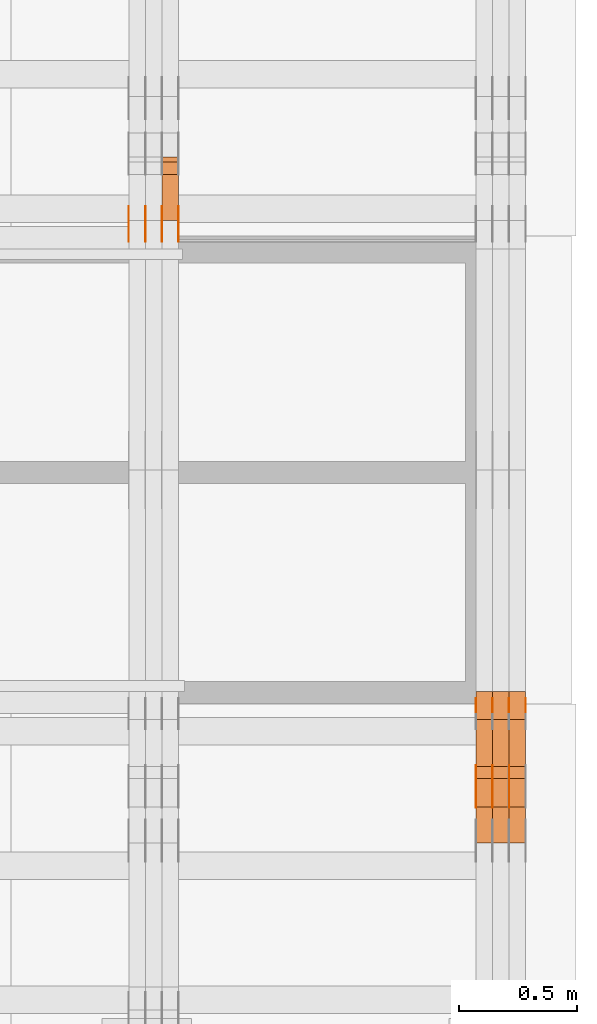
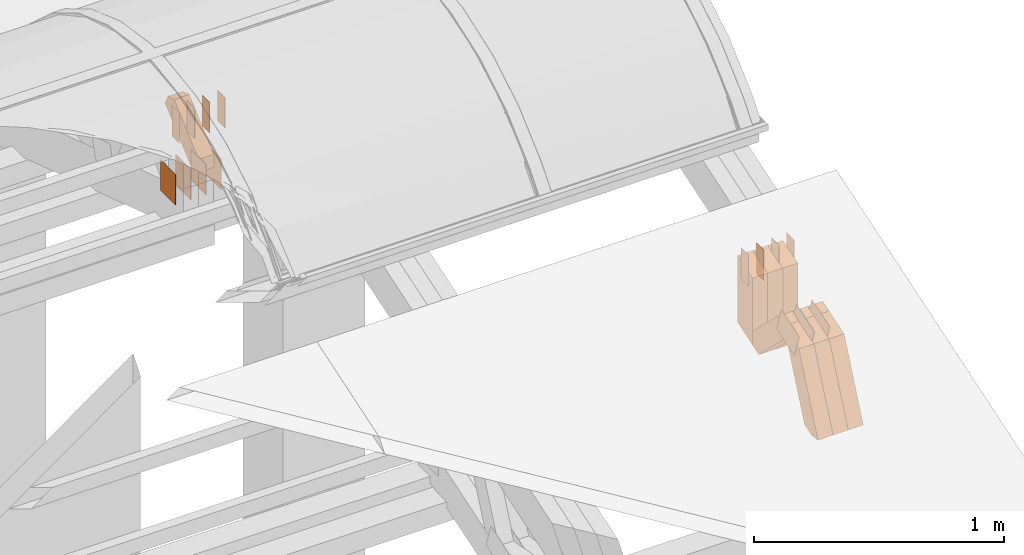
# One storey, part 324 of 385: 32 proxies.
"""IFC2X3 building model written with IfcOpenShell, lengths in millimetres."""

from ifc_helpers import new_model, entity, si_unit, converted_unit, derived_unit, direction, frame, origin, origin_2d_with_axis, place, context, subcontext, project, spatial, polyline, rectangle, outline, extrude, source, transform, mapped, material, type_object, type_shapes, element, save


model = new_model("IFC2X3")

# Units and contexts
model_context = context("Model", 3, precision=0.01, world=origin(), true_north=direction((6.12303176911189e-17, 1.0)))
body_context = subcontext(model_context, "Body", "Model", "MODEL_VIEW")
ifc_project = project(units=[si_unit("LENGTHUNIT", "METRE", prefix="MILLI"), si_unit("AREAUNIT", "SQUARE_METRE"), si_unit("VOLUMEUNIT", "CUBIC_METRE"), converted_unit("PLANEANGLEUNIT", "DEGREE", entity("IfcRatioMeasure", 0.0174532925199433), si_unit("PLANEANGLEUNIT", "RADIAN"), dimensions=[0, 0, 0, 0, 0, 0, 0]), si_unit("MASSUNIT", "GRAM", prefix="KILO"), derived_unit("MASSDENSITYUNIT", [(si_unit("MASSUNIT", "GRAM", prefix="KILO"), 1), (si_unit("LENGTHUNIT", "METRE"), -3)]), si_unit("TIMEUNIT", "SECOND"), si_unit("FREQUENCYUNIT", "HERTZ"), si_unit("THERMODYNAMICTEMPERATUREUNIT", "DEGREE_CELSIUS"), derived_unit("THERMALTRANSMITTANCEUNIT", [(si_unit("MASSUNIT", "GRAM", prefix="KILO"), 1), (si_unit("THERMODYNAMICTEMPERATUREUNIT", "KELVIN"), -1), (si_unit("TIMEUNIT", "SECOND"), -3)]), derived_unit("VOLUMETRICFLOWRATEUNIT", [(si_unit("LENGTHUNIT", "METRE"), 3), (si_unit("TIMEUNIT", "SECOND"), -1)]), si_unit("ELECTRICCURRENTUNIT", "AMPERE"), si_unit("ELECTRICVOLTAGEUNIT", "VOLT"), si_unit("POWERUNIT", "WATT"), si_unit("FORCEUNIT", "NEWTON", prefix="KILO"), si_unit("ILLUMINANCEUNIT", "LUX"), si_unit("LUMINOUSFLUXUNIT", "LUMEN"), si_unit("LUMINOUSINTENSITYUNIT", "CANDELA"), derived_unit("USERDEFINED", [(si_unit("MASSUNIT", "GRAM", prefix="KILO"), -1), (si_unit("LENGTHUNIT", "METRE"), -2), (si_unit("TIMEUNIT", "SECOND"), 3), (si_unit("LUMINOUSFLUXUNIT", "LUMEN"), 1)]), derived_unit("LINEARVELOCITYUNIT", [(si_unit("LENGTHUNIT", "METRE"), 1), (si_unit("TIMEUNIT", "SECOND"), -1)]), si_unit("PRESSUREUNIT", "PASCAL"), derived_unit("USERDEFINED", [(si_unit("LENGTHUNIT", "METRE"), -2), (si_unit("MASSUNIT", "GRAM", prefix="KILO"), 1), (si_unit("TIMEUNIT", "SECOND"), -2)])], contexts=[model_context])

# Site, building, storey
site_placement = place(None, origin())
site = spatial("IfcSite", under=ifc_project, at=site_placement, CompositionType="ELEMENT")
building_placement = place(site_placement, origin())
building = spatial("IfcBuilding", under=site, at=building_placement, CompositionType="ELEMENT")
storey_placement = place(building_placement, origin())
storey = spatial("IfcBuildingStorey", under=building, at=storey_placement, Name="Default", CompositionType="ELEMENT", Elevation=0.0)

# Proxies
ifc_material_1 = material(Name="IfcSurfaceStyle #614002")
building_element_proxy_type_1 = type_object("IfcBuildingElementProxyType", PredefinedType="NOTDEFINED", material=ifc_material_1)
shared_shape_1 = source(origin(), body_context, "Body", "SweptSolid", [
    extrude(outline(polyline([(-74.999875428623, -60.0000016373506), (74.9998605591059, -60.0000016373506), (74.9998754286239, 60.0000016373506), (-74.9998605591068, 60.0000016373506), (-74.999875428623, -60.0000016373506)])), frame((75.0002691827262, 60.0000190504561, 0.0), z_axis=(0.0, 0.0, 1.0), x_axis=(-1.0, 0.0, 0.0)), (0.0, 0.0, 1.0), 1.3),
])
type_shapes(building_element_proxy_type_1, [shared_shape_1])
proxy_1_placement = place(building_placement, frame((49791.3, 13285.0865109705, 3819.37496637467), z_axis=(-1.0, 0.0, 0.0), x_axis=(0.0, 0.951056516295154, 0.309016994374948)))
element("IfcBuildingElementProxy", 1, at=proxy_1_placement, inside=storey, type_object=building_element_proxy_type_1, material=ifc_material_1, context=body_context, shape_type="MappedRepresentation", body=[
    mapped(shared_shape_1, transform((0.0, 0.0, 0.0), scale=1.0)),
])
ifc_material_2 = material(Name="IfcSurfaceStyle #613945")
building_element_proxy_type_2 = type_object("IfcBuildingElementProxyType", PredefinedType="NOTDEFINED", material=ifc_material_2)
shared_shape_2 = source(origin(), body_context, "Body", "SweptSolid", [
    extrude(outline(polyline([(-74.999875428623, -60.0000016373506), (74.9998605591059, -60.0000016373506), (74.9998754286239, 60.0000016373506), (-74.9998605591068, 60.0000016373506), (-74.999875428623, -60.0000016373506)])), frame((75.0002691827262, 60.0000190504561, 0.0), z_axis=(0.0, 0.0, 1.0), x_axis=(-1.0, 0.0, 0.0)), (0.0, 0.0, 1.0), 1.29999999999999),
])
type_shapes(building_element_proxy_type_2, [shared_shape_2])
proxy_2_placement = place(building_placement, frame((49720.0, 13285.0865109705, 3819.37496637467), z_axis=(-1.0, 0.0, 0.0), x_axis=(0.0, 0.951056516295154, 0.309016994374948)))
element("IfcBuildingElementProxy", 2, at=proxy_2_placement, inside=storey, type_object=building_element_proxy_type_2, material=ifc_material_2, context=body_context, shape_type="MappedRepresentation", body=[
    mapped(shared_shape_2, transform((0.0, 0.0, 0.0), scale=1.0)),
])
ifc_material_3 = material(Name="IfcSurfaceStyle #613888")
building_element_proxy_type_3 = type_object("IfcBuildingElementProxyType", PredefinedType="NOTDEFINED", material=ifc_material_3)
shared_shape_3 = source(origin(), body_context, "Body", "SweptSolid", [
    extrude(outline(polyline([(-74.999875428623, -60.0000016373506), (74.9998605591059, -60.0000016373506), (74.9998754286239, 60.0000016373506), (-74.9998605591068, 60.0000016373506), (-74.999875428623, -60.0000016373506)])), frame((75.0002691827262, 60.0000190504561, 0.0), z_axis=(0.0, 0.0, 1.0), x_axis=(-1.0, 0.0, 0.0)), (0.0, 0.0, 1.0), 1.29999999999999),
])
type_shapes(building_element_proxy_type_3, [shared_shape_3])
proxy_3_placement = place(building_placement, frame((49721.3, 13285.0865109705, 3819.37496637467), z_axis=(-1.0, 0.0, 0.0), x_axis=(0.0, 0.951056516295154, 0.309016994374948)))
element("IfcBuildingElementProxy", 3, at=proxy_3_placement, inside=storey, type_object=building_element_proxy_type_3, material=ifc_material_3, context=body_context, shape_type="MappedRepresentation", body=[
    mapped(shared_shape_3, transform((0.0, 0.0, 0.0), scale=1.0)),
])
ifc_material_4 = material(Name="IfcSurfaceStyle #613831")
building_element_proxy_type_4 = type_object("IfcBuildingElementProxyType", PredefinedType="NOTDEFINED", material=ifc_material_4)
shared_shape_4 = source(origin(), body_context, "Body", "SweptSolid", [
    extrude(outline(polyline([(-74.999875428623, -60.0000016373506), (74.9998605591059, -60.0000016373506), (74.9998754286239, 60.0000016373506), (-74.9998605591068, 60.0000016373506), (-74.999875428623, -60.0000016373506)])), frame((75.0002691827262, 60.0000190504561, 0.0), z_axis=(0.0, 0.0, 1.0), x_axis=(-1.0, 0.0, 0.0)), (0.0, 0.0, 1.0), 1.29999999999999),
])
type_shapes(building_element_proxy_type_4, [shared_shape_4])
proxy_4_placement = place(building_placement, frame((49650.0, 13285.0865109705, 3819.37496637467), z_axis=(-1.0, 0.0, 0.0), x_axis=(0.0, 0.951056516295154, 0.309016994374948)))
element("IfcBuildingElementProxy", 4, at=proxy_4_placement, inside=storey, type_object=building_element_proxy_type_4, material=ifc_material_4, context=body_context, shape_type="MappedRepresentation", body=[
    mapped(shared_shape_4, transform((0.0, 0.0, 0.0), scale=1.0)),
])
ifc_material_5 = material(Name="IfcSurfaceStyle #613432")
building_element_proxy_type_5 = type_object("IfcBuildingElementProxyType", PredefinedType="NOTDEFINED", material=ifc_material_5)
shared_shape_5 = source(origin(), body_context, "Body", "SweptSolid", [
    extrude(rectangle(XDim=150.0, YDim=60.0, at=origin_2d_with_axis()), frame((75.0000705696166, 30.0, 0.0), z_axis=(0.0, 0.0, 1.0), x_axis=(-1.0, 0.0, 0.0)), (0.0, 0.0, 1.0), 1.3),
])
type_shapes(building_element_proxy_type_5, [shared_shape_5])
proxy_5_placement = place(building_placement, frame((49861.3, 13750.0, 3972.59919166337), z_axis=(-1.0, 0.0, 0.0), x_axis=(0.0, 0.0, -1.0)))
element("IfcBuildingElementProxy", 5, at=proxy_5_placement, inside=storey, type_object=building_element_proxy_type_5, material=ifc_material_5, context=body_context, shape_type="MappedRepresentation", body=[
    mapped(shared_shape_5, transform((0.0, 0.0, 0.0), scale=1.0)),
])
ifc_material_6 = material(Name="IfcSurfaceStyle #613375")
building_element_proxy_type_6 = type_object("IfcBuildingElementProxyType", PredefinedType="NOTDEFINED", material=ifc_material_6)
shared_shape_6 = source(origin(), body_context, "Body", "SweptSolid", [
    extrude(rectangle(XDim=150.0, YDim=60.0, at=origin_2d_with_axis()), frame((75.0000705696166, 30.0, 0.0), z_axis=(0.0, 0.0, 1.0), x_axis=(-1.0, 0.0, 0.0)), (0.0, 0.0, 1.0), 1.3),
])
type_shapes(building_element_proxy_type_6, [shared_shape_6])
proxy_6_placement = place(building_placement, frame((49790.0, 13750.0, 3972.59919166337), z_axis=(-1.0, 0.0, 0.0), x_axis=(0.0, 0.0, -1.0)))
element("IfcBuildingElementProxy", 6, at=proxy_6_placement, inside=storey, type_object=building_element_proxy_type_6, material=ifc_material_6, context=body_context, shape_type="MappedRepresentation", body=[
    mapped(shared_shape_6, transform((0.0, 0.0, 0.0), scale=1.0)),
])
ifc_material_7 = material(Name="IfcSurfaceStyle #613318")
building_element_proxy_type_7 = type_object("IfcBuildingElementProxyType", PredefinedType="NOTDEFINED", material=ifc_material_7)
shared_shape_7 = source(origin(), body_context, "Body", "SweptSolid", [
    extrude(rectangle(XDim=150.0, YDim=60.0, at=origin_2d_with_axis()), frame((75.0000705696166, 30.0, 0.0), z_axis=(0.0, 0.0, 1.0), x_axis=(-1.0, 0.0, 0.0)), (0.0, 0.0, 1.0), 1.3),
])
type_shapes(building_element_proxy_type_7, [shared_shape_7])
proxy_7_placement = place(building_placement, frame((49791.3, 13750.0, 3972.59919166337), z_axis=(-1.0, 0.0, 0.0), x_axis=(0.0, 0.0, -1.0)))
element("IfcBuildingElementProxy", 7, at=proxy_7_placement, inside=storey, type_object=building_element_proxy_type_7, material=ifc_material_7, context=body_context, shape_type="MappedRepresentation", body=[
    mapped(shared_shape_7, transform((0.0, 0.0, 0.0), scale=1.0)),
])
ifc_material_8 = material(Name="IfcSurfaceStyle #613261")
building_element_proxy_type_8 = type_object("IfcBuildingElementProxyType", PredefinedType="NOTDEFINED", material=ifc_material_8)
shared_shape_8 = source(origin(), body_context, "Body", "SweptSolid", [
    extrude(rectangle(XDim=150.0, YDim=60.0, at=origin_2d_with_axis()), frame((75.0000705696166, 30.0, 0.0), z_axis=(0.0, 0.0, 1.0), x_axis=(-1.0, 0.0, 0.0)), (0.0, 0.0, 1.0), 1.29999999999999),
])
type_shapes(building_element_proxy_type_8, [shared_shape_8])
proxy_8_placement = place(building_placement, frame((49720.0, 13750.0, 3972.59919166337), z_axis=(-1.0, 0.0, 0.0), x_axis=(0.0, 0.0, -1.0)))
element("IfcBuildingElementProxy", 8, at=proxy_8_placement, inside=storey, type_object=building_element_proxy_type_8, material=ifc_material_8, context=body_context, shape_type="MappedRepresentation", body=[
    mapped(shared_shape_8, transform((0.0, 0.0, 0.0), scale=1.0)),
])
ifc_material_9 = material(Name="IfcSurfaceStyle #613204")
building_element_proxy_type_9 = type_object("IfcBuildingElementProxyType", PredefinedType="NOTDEFINED", material=ifc_material_9)
shared_shape_9 = source(origin(), body_context, "Body", "SweptSolid", [
    extrude(rectangle(XDim=150.0, YDim=60.0, at=origin_2d_with_axis()), frame((75.0000705696166, 30.0, 0.0), z_axis=(0.0, 0.0, 1.0), x_axis=(-1.0, 0.0, 0.0)), (0.0, 0.0, 1.0), 1.29999999999999),
])
type_shapes(building_element_proxy_type_9, [shared_shape_9])
proxy_9_placement = place(building_placement, frame((49721.3, 13750.0, 3972.59919166337), z_axis=(-1.0, 0.0, 0.0), x_axis=(0.0, 0.0, -1.0)))
element("IfcBuildingElementProxy", 9, at=proxy_9_placement, inside=storey, type_object=building_element_proxy_type_9, material=ifc_material_9, context=body_context, shape_type="MappedRepresentation", body=[
    mapped(shared_shape_9, transform((0.0, 0.0, 0.0), scale=1.0)),
])
ifc_material_10 = material(Name="IfcSurfaceStyle #613147")
building_element_proxy_type_10 = type_object("IfcBuildingElementProxyType", PredefinedType="NOTDEFINED", material=ifc_material_10)
shared_shape_10 = source(origin(), body_context, "Body", "SweptSolid", [
    extrude(rectangle(XDim=150.0, YDim=60.0, at=origin_2d_with_axis()), frame((75.0000705696166, 30.0, 0.0), z_axis=(0.0, 0.0, 1.0), x_axis=(-1.0, 0.0, 0.0)), (0.0, 0.0, 1.0), 1.29999999999999),
])
type_shapes(building_element_proxy_type_10, [shared_shape_10])
proxy_10_placement = place(building_placement, frame((49650.0, 13750.0, 3972.59919166337), z_axis=(-1.0, 0.0, 0.0), x_axis=(0.0, 0.0, -1.0)))
element("IfcBuildingElementProxy", 10, at=proxy_10_placement, inside=storey, type_object=building_element_proxy_type_10, material=ifc_material_10, context=body_context, shape_type="MappedRepresentation", body=[
    mapped(shared_shape_10, transform((0.0, 0.0, 0.0), scale=1.0)),
])
ifc_material_11 = material(Name="IfcSurfaceStyle #603946")
building_element_proxy_type_11 = type_object("IfcBuildingElementProxyType", Name="T2-W49 603944", PredefinedType="NOTDEFINED", material=ifc_material_11)
shared_shape_11 = source(origin(), body_context, "Body", "SweptSolid", [
    extrude(outline(polyline([(-155.175867306415, -47.4997478409253), (152.310664695054, -47.4997478409253), (170.496756790954, -6.14570120142345e-05), (145.70957993751, 47.4998092979374), (-133.37808995724, 47.4998092979373), (-179.963044159863, -6.14570120298391e-05), (-155.175867306415, -47.4997478409253)])), frame((170.496756790954, 47.5001152140455, 0.0), z_axis=(0.0, 0.0, 1.0), x_axis=(-1.0, 0.0, 0.0)), (0.0, 0.0, 1.0), 70.0),
])
type_shapes(building_element_proxy_type_11, [shared_shape_11])
proxy_11_placement = place(building_placement, frame((49860.0, 13443.048524104, 3830.71841973934), z_axis=(-1.0, 0.0, 0.0), x_axis=(0.0, 0.713950095632063, -0.700196587357413)))
element("IfcBuildingElementProxy", 11, at=proxy_11_placement, inside=storey, type_object=building_element_proxy_type_11, material=ifc_material_11, Name="T2-W49", context=body_context, shape_type="MappedRepresentation", body=[
    mapped(shared_shape_11, transform((0.0, 0.0, 0.0), scale=1.0)),
])
ifc_material_12 = material(Name="IfcSurfaceStyle #603871")
building_element_proxy_type_12 = type_object("IfcBuildingElementProxyType", Name="T2-W49 603869", PredefinedType="NOTDEFINED", material=ifc_material_12)
shared_shape_12 = source(origin(), body_context, "Body", "SweptSolid", [
    extrude(outline(polyline([(-155.175867306415, -47.4997478409253), (152.310664695054, -47.4997478409253), (170.496756790954, -6.14570120142345e-05), (145.70957993751, 47.4998092979374), (-133.37808995724, 47.4998092979373), (-179.963044159863, -6.14570120298391e-05), (-155.175867306415, -47.4997478409253)])), frame((170.496756790954, 47.5001152140455, 0.0), z_axis=(0.0, 0.0, 1.0), x_axis=(-1.0, 0.0, 0.0)), (0.0, 0.0, 1.0), 70.0),
])
type_shapes(building_element_proxy_type_12, [shared_shape_12])
proxy_12_placement = place(building_placement, frame((49790.0, 13443.048524104, 3830.71841973934), z_axis=(-1.0, 0.0, 0.0), x_axis=(0.0, 0.713950095632063, -0.700196587357413)))
element("IfcBuildingElementProxy", 12, at=proxy_12_placement, inside=storey, type_object=building_element_proxy_type_12, material=ifc_material_12, Name="T2-W49", context=body_context, shape_type="MappedRepresentation", body=[
    mapped(shared_shape_12, transform((0.0, 0.0, 0.0), scale=1.0)),
])
ifc_material_13 = material(Name="IfcSurfaceStyle #603796")
building_element_proxy_type_13 = type_object("IfcBuildingElementProxyType", Name="T2-W49 603794", PredefinedType="NOTDEFINED", material=ifc_material_13)
shared_shape_13 = source(origin(), body_context, "Body", "SweptSolid", [
    extrude(outline(polyline([(-155.175867306415, -47.4997478409253), (152.310664695054, -47.4997478409253), (170.496756790954, -6.14570120142345e-05), (145.70957993751, 47.4998092979374), (-133.37808995724, 47.4998092979373), (-179.963044159863, -6.14570120298391e-05), (-155.175867306415, -47.4997478409253)])), frame((170.496756790954, 47.5001152140455, 0.0), z_axis=(0.0, 0.0, 1.0), x_axis=(-1.0, 0.0, 0.0)), (0.0, 0.0, 1.0), 70.0),
])
type_shapes(building_element_proxy_type_13, [shared_shape_13])
proxy_13_placement = place(building_placement, frame((49720.0, 13443.048524104, 3830.71841973934), z_axis=(-1.0, 0.0, 0.0), x_axis=(0.0, 0.713950095632063, -0.700196587357413)))
element("IfcBuildingElementProxy", 13, at=proxy_13_placement, inside=storey, type_object=building_element_proxy_type_13, material=ifc_material_13, Name="T2-W49", context=body_context, shape_type="MappedRepresentation", body=[
    mapped(shared_shape_13, transform((0.0, 0.0, 0.0), scale=1.0)),
])
ifc_material_14 = material(Name="IfcSurfaceStyle #603496")
building_element_proxy_type_14 = type_object("IfcBuildingElementProxyType", Name="T2-W1 603494", PredefinedType="NOTDEFINED", material=ifc_material_14)
shared_shape_14 = source(origin(), body_context, "Body", "SweptSolid", [
    extrude(outline(polyline([(-182.839782714844, -60.0), (143.849426269531, -60.0), (182.839660644531, 60.0), (-143.849304199219, 60.0), (-182.839782714844, -60.0)])), frame((182.839674685549, 60.0, 0.0), z_axis=(0.0, 0.0, 1.0), x_axis=(-1.0, 0.0, 0.0)), (0.0, 0.0, 1.0), 70.0),
])
type_shapes(building_element_proxy_type_14, [shared_shape_14])
proxy_14_placement = place(building_placement, frame((49860.0, 13660.0, 3551.41502502148), z_axis=(-1.0, 0.0, 0.0), x_axis=(0.0, 0.0, 1.0)))
element("IfcBuildingElementProxy", 14, at=proxy_14_placement, inside=storey, type_object=building_element_proxy_type_14, material=ifc_material_14, Name="T2-W1", context=body_context, shape_type="MappedRepresentation", body=[
    mapped(shared_shape_14, transform((0.0, 0.0, 0.0), scale=1.0)),
])
ifc_material_15 = material(Name="IfcSurfaceStyle #603439")
building_element_proxy_type_15 = type_object("IfcBuildingElementProxyType", Name="T2-W1 603437", PredefinedType="NOTDEFINED", material=ifc_material_15)
shared_shape_15 = source(origin(), body_context, "Body", "SweptSolid", [
    extrude(outline(polyline([(-182.839782714844, -60.0), (143.849426269531, -60.0), (182.839660644531, 60.0), (-143.849304199219, 60.0), (-182.839782714844, -60.0)])), frame((182.839674685549, 60.0, 0.0), z_axis=(0.0, 0.0, 1.0), x_axis=(-1.0, 0.0, 0.0)), (0.0, 0.0, 1.0), 70.0),
])
type_shapes(building_element_proxy_type_15, [shared_shape_15])
proxy_15_placement = place(building_placement, frame((49790.0, 13660.0, 3551.41502502148), z_axis=(-1.0, 0.0, 0.0), x_axis=(0.0, 0.0, 1.0)))
element("IfcBuildingElementProxy", 15, at=proxy_15_placement, inside=storey, type_object=building_element_proxy_type_15, material=ifc_material_15, Name="T2-W1", context=body_context, shape_type="MappedRepresentation", body=[
    mapped(shared_shape_15, transform((0.0, 0.0, 0.0), scale=1.0)),
])
ifc_material_16 = material(Name="IfcSurfaceStyle #603382")
building_element_proxy_type_16 = type_object("IfcBuildingElementProxyType", Name="T2-W1 603380", PredefinedType="NOTDEFINED", material=ifc_material_16)
shared_shape_16 = source(origin(), body_context, "Body", "SweptSolid", [
    extrude(outline(polyline([(-182.839782714844, -60.0), (143.849426269531, -60.0), (182.839660644531, 60.0), (-143.849304199219, 60.0), (-182.839782714844, -60.0)])), frame((182.839674685549, 60.0, 0.0), z_axis=(0.0, 0.0, 1.0), x_axis=(-1.0, 0.0, 0.0)), (0.0, 0.0, 1.0), 70.0),
])
type_shapes(building_element_proxy_type_16, [shared_shape_16])
proxy_16_placement = place(building_placement, frame((49720.0, 13660.0, 3551.41502502148), z_axis=(-1.0, 0.0, 0.0), x_axis=(0.0, 0.0, 1.0)))
element("IfcBuildingElementProxy", 16, at=proxy_16_placement, inside=storey, type_object=building_element_proxy_type_16, material=ifc_material_16, Name="T2-W1", context=body_context, shape_type="MappedRepresentation", body=[
    mapped(shared_shape_16, transform((0.0, 0.0, 0.0), scale=1.0)),
])
ifc_material_17 = material(Name="IfcSurfaceStyle #602956")
building_element_proxy_type_17 = type_object("IfcBuildingElementProxyType", Name="T2-W42 602954", PredefinedType="NOTDEFINED", material=ifc_material_17)
shared_shape_17 = source(origin(), body_context, "Body", "SweptSolid", [
    extrude(outline(polyline([(-284.837590197601, -47.4997543607933), (129.95880168156, -47.4997543607933), (171.972324990451, 0.000162623346093338), (183.717007105413, 47.4996730491203), (-200.810543579822, 47.4996730491203), (-284.837590197601, -47.4997543607933)])), frame((183.717155718752, 47.4999821655365, 0.0), z_axis=(0.0, 0.0, 1.0), x_axis=(-1.0, 0.0, 0.0)), (0.0, 0.0, 1.0), 70.0),
])
type_shapes(building_element_proxy_type_17, [shared_shape_17])
proxy_17_placement = place(building_placement, frame((49860.0, 13135.8834463264, 3404.958483022), z_axis=(-1.0, 0.0, 0.0), x_axis=(0.0, 0.398630596470292, 0.917111578575769)))
element("IfcBuildingElementProxy", 17, at=proxy_17_placement, inside=storey, type_object=building_element_proxy_type_17, material=ifc_material_17, Name="T2-W42", context=body_context, shape_type="MappedRepresentation", body=[
    mapped(shared_shape_17, transform((0.0, 0.0, 0.0), scale=1.0)),
])
ifc_material_18 = material(Name="IfcSurfaceStyle #602890")
building_element_proxy_type_18 = type_object("IfcBuildingElementProxyType", Name="T2-W42 602888", PredefinedType="NOTDEFINED", material=ifc_material_18)
shared_shape_18 = source(origin(), body_context, "Body", "SweptSolid", [
    extrude(outline(polyline([(-284.837590197601, -47.4997543607933), (129.95880168156, -47.4997543607933), (171.972324990451, 0.000162623346093338), (183.717007105413, 47.4996730491203), (-200.810543579822, 47.4996730491203), (-284.837590197601, -47.4997543607933)])), frame((183.717155718752, 47.4999821655365, 0.0), z_axis=(0.0, 0.0, 1.0), x_axis=(-1.0, 0.0, 0.0)), (0.0, 0.0, 1.0), 70.0),
])
type_shapes(building_element_proxy_type_18, [shared_shape_18])
proxy_18_placement = place(building_placement, frame((49790.0, 13135.8834463264, 3404.958483022), z_axis=(-1.0, 0.0, 0.0), x_axis=(0.0, 0.398630596470292, 0.917111578575769)))
element("IfcBuildingElementProxy", 18, at=proxy_18_placement, inside=storey, type_object=building_element_proxy_type_18, material=ifc_material_18, Name="T2-W42", context=body_context, shape_type="MappedRepresentation", body=[
    mapped(shared_shape_18, transform((0.0, 0.0, 0.0), scale=1.0)),
])
ifc_material_19 = material(Name="IfcSurfaceStyle #602824")
building_element_proxy_type_19 = type_object("IfcBuildingElementProxyType", Name="T2-W42 602822", PredefinedType="NOTDEFINED", material=ifc_material_19)
shared_shape_19 = source(origin(), body_context, "Body", "SweptSolid", [
    extrude(outline(polyline([(-284.837590197601, -47.4997543607933), (129.95880168156, -47.4997543607933), (171.972324990451, 0.000162623346093338), (183.717007105413, 47.4996730491203), (-200.810543579822, 47.4996730491203), (-284.837590197601, -47.4997543607933)])), frame((183.717155718752, 47.4999821655365, 0.0), z_axis=(0.0, 0.0, 1.0), x_axis=(-1.0, 0.0, 0.0)), (0.0, 0.0, 1.0), 70.0),
])
type_shapes(building_element_proxy_type_19, [shared_shape_19])
proxy_19_placement = place(building_placement, frame((49720.0, 13135.8834463264, 3404.958483022), z_axis=(-1.0, 0.0, 0.0), x_axis=(0.0, 0.398630596470292, 0.917111578575769)))
element("IfcBuildingElementProxy", 19, at=proxy_19_placement, inside=storey, type_object=building_element_proxy_type_19, material=ifc_material_19, Name="T2-W42", context=body_context, shape_type="MappedRepresentation", body=[
    mapped(shared_shape_19, transform((0.0, 0.0, 0.0), scale=1.0)),
])
ifc_material_20 = material(Name="IfcSurfaceStyle #584130")
building_element_proxy_type_20 = type_object("IfcBuildingElementProxyType", PredefinedType="NOTDEFINED", material=ifc_material_20)
shared_shape_20 = source(origin(), body_context, "Body", "SweptSolid", [
    extrude(rectangle(XDim=150.0, YDim=120.0, at=origin_2d_with_axis()), frame((75.0, 60.0, 0.0), z_axis=(0.0, 0.0, 1.0), x_axis=(-1.0, 0.0, 0.0)), (0.0, 0.0, 1.0), 1.3),
])
type_shapes(building_element_proxy_type_20, [shared_shape_20])
proxy_20_placement = place(building_placement, frame((48386.3, 15840.0, 3652.70166015625), z_axis=(-1.0, 0.0, 0.0), x_axis=(0.0, 0.0, -1.0)))
element("IfcBuildingElementProxy", 20, at=proxy_20_placement, inside=storey, type_object=building_element_proxy_type_20, material=ifc_material_20, context=body_context, shape_type="MappedRepresentation", body=[
    mapped(shared_shape_20, transform((0.0, 0.0, 0.0), scale=1.0)),
])
ifc_material_21 = material(Name="IfcSurfaceStyle #584073")
building_element_proxy_type_21 = type_object("IfcBuildingElementProxyType", PredefinedType="NOTDEFINED", material=ifc_material_21)
shared_shape_21 = source(origin(), body_context, "Body", "SweptSolid", [
    extrude(rectangle(XDim=150.0, YDim=120.0, at=origin_2d_with_axis()), frame((75.0, 60.0, 0.0), z_axis=(0.0, 0.0, 1.0), x_axis=(-1.0, 0.0, 0.0)), (0.0, 0.0, 1.0), 1.3),
])
type_shapes(building_element_proxy_type_21, [shared_shape_21])
proxy_21_placement = place(building_placement, frame((48315.0, 15840.0, 3652.70166015625), z_axis=(-1.0, 0.0, 0.0), x_axis=(0.0, 0.0, -1.0)))
element("IfcBuildingElementProxy", 21, at=proxy_21_placement, inside=storey, type_object=building_element_proxy_type_21, material=ifc_material_21, context=body_context, shape_type="MappedRepresentation", body=[
    mapped(shared_shape_21, transform((0.0, 0.0, 0.0), scale=1.0)),
])
ifc_material_22 = material(Name="IfcSurfaceStyle #584016")
building_element_proxy_type_22 = type_object("IfcBuildingElementProxyType", PredefinedType="NOTDEFINED", material=ifc_material_22)
shared_shape_22 = source(origin(), body_context, "Body", "SweptSolid", [
    extrude(rectangle(XDim=150.0, YDim=120.0, at=origin_2d_with_axis()), frame((75.0, 60.0, 0.0), z_axis=(0.0, 0.0, 1.0), x_axis=(-1.0, 0.0, 0.0)), (0.0, 0.0, 1.0), 1.3),
])
type_shapes(building_element_proxy_type_22, [shared_shape_22])
proxy_22_placement = place(building_placement, frame((48316.3, 15840.0, 3652.70166015625), z_axis=(-1.0, 0.0, 0.0), x_axis=(0.0, 0.0, -1.0)))
element("IfcBuildingElementProxy", 22, at=proxy_22_placement, inside=storey, type_object=building_element_proxy_type_22, material=ifc_material_22, context=body_context, shape_type="MappedRepresentation", body=[
    mapped(shared_shape_22, transform((0.0, 0.0, 0.0), scale=1.0)),
])
ifc_material_23 = material(Name="IfcSurfaceStyle #583959")
building_element_proxy_type_23 = type_object("IfcBuildingElementProxyType", PredefinedType="NOTDEFINED", material=ifc_material_23)
shared_shape_23 = source(origin(), body_context, "Body", "SweptSolid", [
    extrude(rectangle(XDim=150.0, YDim=120.0, at=origin_2d_with_axis()), frame((75.0, 60.0, 0.0), z_axis=(0.0, 0.0, 1.0), x_axis=(-1.0, 0.0, 0.0)), (0.0, 0.0, 1.0), 1.29999999999999),
])
type_shapes(building_element_proxy_type_23, [shared_shape_23])
proxy_23_placement = place(building_placement, frame((48245.0, 15840.0, 3652.70166015625), z_axis=(-1.0, 0.0, 0.0), x_axis=(0.0, 0.0, -1.0)))
element("IfcBuildingElementProxy", 23, at=proxy_23_placement, inside=storey, type_object=building_element_proxy_type_23, material=ifc_material_23, context=body_context, shape_type="MappedRepresentation", body=[
    mapped(shared_shape_23, transform((0.0, 0.0, 0.0), scale=1.0)),
])
ifc_material_24 = material(Name="IfcSurfaceStyle #583902")
building_element_proxy_type_24 = type_object("IfcBuildingElementProxyType", PredefinedType="NOTDEFINED", material=ifc_material_24)
shared_shape_24 = source(origin(), body_context, "Body", "SweptSolid", [
    extrude(rectangle(XDim=150.0, YDim=120.0, at=origin_2d_with_axis()), frame((75.0, 60.0, 0.0), z_axis=(0.0, 0.0, 1.0), x_axis=(-1.0, 0.0, 0.0)), (0.0, 0.0, 1.0), 1.29999999999999),
])
type_shapes(building_element_proxy_type_24, [shared_shape_24])
proxy_24_placement = place(building_placement, frame((48246.3, 15840.0, 3652.70166015625), z_axis=(-1.0, 0.0, 0.0), x_axis=(0.0, 0.0, -1.0)))
element("IfcBuildingElementProxy", 24, at=proxy_24_placement, inside=storey, type_object=building_element_proxy_type_24, material=ifc_material_24, context=body_context, shape_type="MappedRepresentation", body=[
    mapped(shared_shape_24, transform((0.0, 0.0, 0.0), scale=1.0)),
])
ifc_material_25 = material(Name="IfcSurfaceStyle #583845")
building_element_proxy_type_25 = type_object("IfcBuildingElementProxyType", PredefinedType="NOTDEFINED", material=ifc_material_25)
shared_shape_25 = source(origin(), body_context, "Body", "SweptSolid", [
    extrude(rectangle(XDim=150.0, YDim=120.0, at=origin_2d_with_axis()), frame((75.0, 60.0, 0.0), z_axis=(0.0, 0.0, 1.0), x_axis=(-1.0, 0.0, 0.0)), (0.0, 0.0, 1.0), 1.29999999999999),
])
type_shapes(building_element_proxy_type_25, [shared_shape_25])
proxy_25_placement = place(building_placement, frame((48175.0, 15840.0, 3652.70166015625), z_axis=(-1.0, 0.0, 0.0), x_axis=(0.0, 0.0, -1.0)))
element("IfcBuildingElementProxy", 25, at=proxy_25_placement, inside=storey, type_object=building_element_proxy_type_25, material=ifc_material_25, context=body_context, shape_type="MappedRepresentation", body=[
    mapped(shared_shape_25, transform((0.0, 0.0, 0.0), scale=1.0)),
])
ifc_material_26 = material(Name="IfcSurfaceStyle #578658")
building_element_proxy_type_26 = type_object("IfcBuildingElementProxyType", PredefinedType="NOTDEFINED", material=ifc_material_26)
shared_shape_26 = source(origin(), body_context, "Body", "SweptSolid", [
    extrude(rectangle(XDim=150.0, YDim=60.0, at=origin_2d_with_axis()), frame((75.0000705696311, 30.0, 0.0), z_axis=(0.0, 0.0, 1.0), x_axis=(-1.0, 0.0, 0.0)), (0.0, 0.0, 1.0), 1.3),
])
type_shapes(building_element_proxy_type_26, [shared_shape_26])
proxy_26_placement = place(building_placement, frame((48386.3, 15750.0, 3972.59919166338), z_axis=(-1.0, 0.0, 0.0), x_axis=(0.0, 0.0, -1.0)))
element("IfcBuildingElementProxy", 26, at=proxy_26_placement, inside=storey, type_object=building_element_proxy_type_26, material=ifc_material_26, context=body_context, shape_type="MappedRepresentation", body=[
    mapped(shared_shape_26, transform((0.0, 0.0, 0.0), scale=1.0)),
])
ifc_material_27 = material(Name="IfcSurfaceStyle #578601")
building_element_proxy_type_27 = type_object("IfcBuildingElementProxyType", PredefinedType="NOTDEFINED", material=ifc_material_27)
shared_shape_27 = source(origin(), body_context, "Body", "SweptSolid", [
    extrude(rectangle(XDim=150.0, YDim=60.0, at=origin_2d_with_axis()), frame((75.0000705696311, 30.0, 0.0), z_axis=(0.0, 0.0, 1.0), x_axis=(-1.0, 0.0, 0.0)), (0.0, 0.0, 1.0), 1.3),
])
type_shapes(building_element_proxy_type_27, [shared_shape_27])
proxy_27_placement = place(building_placement, frame((48315.0, 15750.0, 3972.59919166338), z_axis=(-1.0, 0.0, 0.0), x_axis=(0.0, 0.0, -1.0)))
element("IfcBuildingElementProxy", 27, at=proxy_27_placement, inside=storey, type_object=building_element_proxy_type_27, material=ifc_material_27, context=body_context, shape_type="MappedRepresentation", body=[
    mapped(shared_shape_27, transform((0.0, 0.0, 0.0), scale=1.0)),
])
ifc_material_28 = material(Name="IfcSurfaceStyle #578544")
building_element_proxy_type_28 = type_object("IfcBuildingElementProxyType", PredefinedType="NOTDEFINED", material=ifc_material_28)
shared_shape_28 = source(origin(), body_context, "Body", "SweptSolid", [
    extrude(rectangle(XDim=150.0, YDim=60.0, at=origin_2d_with_axis()), frame((75.0000705696311, 30.0, 0.0), z_axis=(0.0, 0.0, 1.0), x_axis=(-1.0, 0.0, 0.0)), (0.0, 0.0, 1.0), 1.3),
])
type_shapes(building_element_proxy_type_28, [shared_shape_28])
proxy_28_placement = place(building_placement, frame((48316.3, 15750.0, 3972.59919166338), z_axis=(-1.0, 0.0, 0.0), x_axis=(0.0, 0.0, -1.0)))
element("IfcBuildingElementProxy", 28, at=proxy_28_placement, inside=storey, type_object=building_element_proxy_type_28, material=ifc_material_28, context=body_context, shape_type="MappedRepresentation", body=[
    mapped(shared_shape_28, transform((0.0, 0.0, 0.0), scale=1.0)),
])
ifc_material_29 = material(Name="IfcSurfaceStyle #578487")
building_element_proxy_type_29 = type_object("IfcBuildingElementProxyType", PredefinedType="NOTDEFINED", material=ifc_material_29)
shared_shape_29 = source(origin(), body_context, "Body", "SweptSolid", [
    extrude(rectangle(XDim=150.0, YDim=60.0, at=origin_2d_with_axis()), frame((75.0000705696311, 30.0, 0.0), z_axis=(0.0, 0.0, 1.0), x_axis=(-1.0, 0.0, 0.0)), (0.0, 0.0, 1.0), 1.29999999999999),
])
type_shapes(building_element_proxy_type_29, [shared_shape_29])
proxy_29_placement = place(building_placement, frame((48245.0, 15750.0, 3972.59919166338), z_axis=(-1.0, 0.0, 0.0), x_axis=(0.0, 0.0, -1.0)))
element("IfcBuildingElementProxy", 29, at=proxy_29_placement, inside=storey, type_object=building_element_proxy_type_29, material=ifc_material_29, context=body_context, shape_type="MappedRepresentation", body=[
    mapped(shared_shape_29, transform((0.0, 0.0, 0.0), scale=1.0)),
])
ifc_material_30 = material(Name="IfcSurfaceStyle #578430")
building_element_proxy_type_30 = type_object("IfcBuildingElementProxyType", PredefinedType="NOTDEFINED", material=ifc_material_30)
shared_shape_30 = source(origin(), body_context, "Body", "SweptSolid", [
    extrude(rectangle(XDim=150.0, YDim=60.0, at=origin_2d_with_axis()), frame((75.0000705696311, 30.0, 0.0), z_axis=(0.0, 0.0, 1.0), x_axis=(-1.0, 0.0, 0.0)), (0.0, 0.0, 1.0), 1.29999999999999),
])
type_shapes(building_element_proxy_type_30, [shared_shape_30])
proxy_30_placement = place(building_placement, frame((48246.3, 15750.0, 3972.59919166338), z_axis=(-1.0, 0.0, 0.0), x_axis=(0.0, 0.0, -1.0)))
element("IfcBuildingElementProxy", 30, at=proxy_30_placement, inside=storey, type_object=building_element_proxy_type_30, material=ifc_material_30, context=body_context, shape_type="MappedRepresentation", body=[
    mapped(shared_shape_30, transform((0.0, 0.0, 0.0), scale=1.0)),
])
ifc_material_31 = material(Name="IfcSurfaceStyle #578373")
building_element_proxy_type_31 = type_object("IfcBuildingElementProxyType", PredefinedType="NOTDEFINED", material=ifc_material_31)
shared_shape_31 = source(origin(), body_context, "Body", "SweptSolid", [
    extrude(rectangle(XDim=150.0, YDim=60.0, at=origin_2d_with_axis()), frame((75.0000705696311, 30.0, 0.0), z_axis=(0.0, 0.0, 1.0), x_axis=(-1.0, 0.0, 0.0)), (0.0, 0.0, 1.0), 1.29999999999999),
])
type_shapes(building_element_proxy_type_31, [shared_shape_31])
proxy_31_placement = place(building_placement, frame((48175.0, 15750.0, 3972.59919166338), z_axis=(-1.0, 0.0, 0.0), x_axis=(0.0, 0.0, -1.0)))
element("IfcBuildingElementProxy", 31, at=proxy_31_placement, inside=storey, type_object=building_element_proxy_type_31, material=ifc_material_31, context=body_context, shape_type="MappedRepresentation", body=[
    mapped(shared_shape_31, transform((0.0, 0.0, 0.0), scale=1.0)),
])
ifc_material_32 = material(Name="IfcSurfaceStyle #569289")
building_element_proxy_type_32 = type_object("IfcBuildingElementProxyType", Name="T1-W50 569287", PredefinedType="NOTDEFINED", material=ifc_material_32)
shared_shape_32 = source(origin(), body_context, "Body", "SweptSolid", [
    extrude(outline(polyline([(-128.56619634284, -47.4999385885712), (133.151257249084, -47.4999385885712), (161.172800006526, -0.000129729183733609), (147.291467726413, 47.500068317755), (-142.513973767368, 47.500068317755), (-170.535354871815, -0.000129729183754689), (-128.56619634284, -47.4999385885712)])), frame((161.17310141218, 47.5001898716564, 0.0), z_axis=(0.0, 0.0, 1.0), x_axis=(-1.0, 0.0, 0.0)), (0.0, 0.0, 1.0), 70.0),
])
type_shapes(building_element_proxy_type_32, [shared_shape_32])
proxy_32_placement = place(building_placement, frame((48385.0, 16060.0297689714, 3761.73994820667), z_axis=(-1.0, 0.0, 0.0), x_axis=(0.0, -0.749388407538668, -0.662130662820156)))
element("IfcBuildingElementProxy", 32, at=proxy_32_placement, inside=storey, type_object=building_element_proxy_type_32, material=ifc_material_32, Name="T1-W50", context=body_context, shape_type="MappedRepresentation", body=[
    mapped(shared_shape_32, transform((0.0, 0.0, 0.0), scale=1.0)),
])

save(model, "model.ifc")
